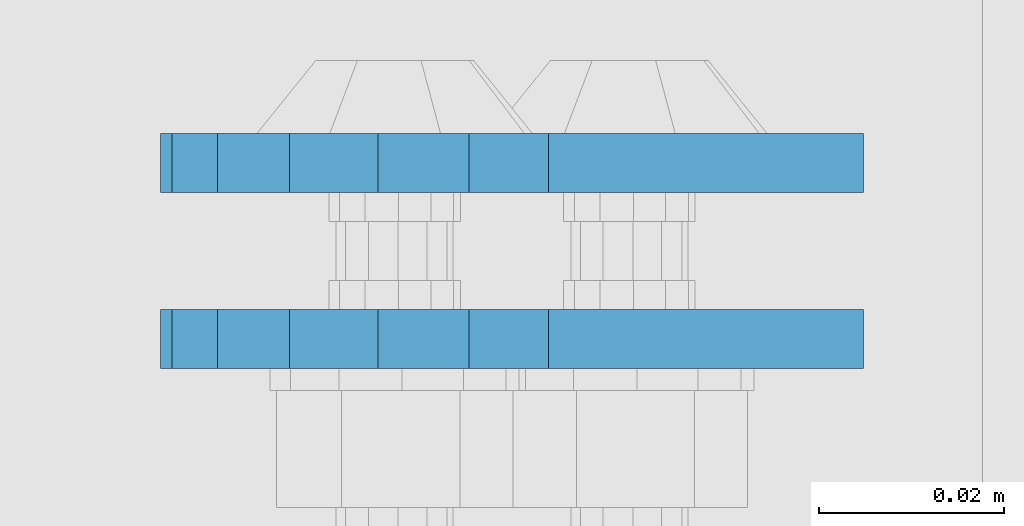
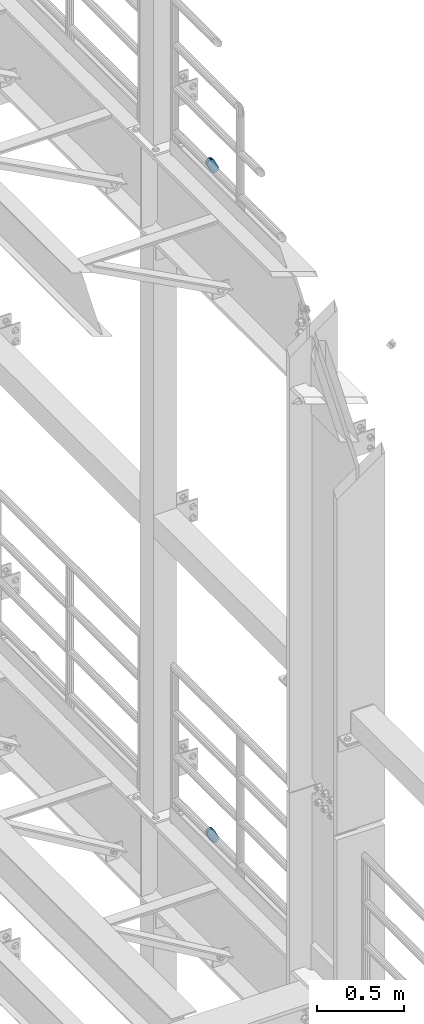
# One storey, part 1817 of 1876: 4 plates, 4 elements without a shape of their own.
"""IFC2X3 building model written with IfcOpenShell, lengths in millimetres."""

from ifc_helpers import new_model, si_unit, frame, origin_with_axes, place, context, subcontext, project, spatial, faceted_brep, material, type_object, element, aggregate, save


model = new_model("IFC2X3")

# Units and contexts
model_context = context("Model", 3, precision=1e-05, world=origin_with_axes())
body_context = subcontext(model_context, "Body", "Model", "MODEL_VIEW")
ifc_project = project(units=[si_unit("LENGTHUNIT", "METRE", prefix="MILLI"), si_unit("AREAUNIT", "SQUARE_METRE"), si_unit("VOLUMEUNIT", "CUBIC_METRE"), si_unit("MASSUNIT", "GRAM", prefix="KILO"), si_unit("TIMEUNIT", "SECOND"), si_unit("PLANEANGLEUNIT", "RADIAN"), si_unit("SOLIDANGLEUNIT", "STERADIAN"), si_unit("THERMODYNAMICTEMPERATUREUNIT", "DEGREE_CELSIUS"), si_unit("LUMINOUSINTENSITYUNIT", "LUMEN")], contexts=[model_context])

# Site, building, storey
site_placement = place(None, origin_with_axes())
site = spatial("IfcSite", under=ifc_project, at=site_placement, CompositionType="ELEMENT")
building_placement = place(site_placement, origin_with_axes())
building = spatial("IfcBuilding", under=site, at=building_placement, Name="Undefined", CompositionType="ELEMENT")
storey_placement = place(building_placement, origin_with_axes())
storey = spatial("IfcBuildingStorey", under=building, at=storey_placement, Name="Undefined", CompositionType="ELEMENT", Elevation=0.0)

# Assembly, plate
assembly_1_placement = place(storey_placement, origin_with_axes())
assembly_1 = element("IfcElementAssembly", 1, at=assembly_1_placement, inside=storey, Name="PLATE", AssemblyPlace="NOTDEFINED", PredefinedType="RIGID_FRAME")
ifc_material = material(Name="STEEL/A36")
plate_type = type_object("IfcPlateType", PredefinedType="NOTDEFINED")
plate_1_placement = place(assembly_1_placement, frame((7974.16265107448, 9642.4750023123, 17725.1776774809), z_axis=(-0.894427191199917, 1.49999996210681e-08, -0.447213595099955), x_axis=(0.447213595099955, -6.99999707257281e-09, -0.894427191199917)))
plate_1 = element("IfcPlate", 2, at=plate_1_placement, type_object=plate_type, material=ifc_material, Name="PLATE", context=body_context, shape_type="Brep", body=[
    faceted_brep([(-8.59611645864788e-07, -3.17499999999654, 25.3999987589127), (1.93345873884391, -3.17499999999382, 35.1201580589886), (1.93345873884391, 3.17500000000564, 35.1201580589886), (-8.59611645864788e-07, 3.17500000000382, 25.3999987589132), (7.43948648259902, -3.17499999999109, 43.3605112870105), (7.43948648259902, 3.17500000000928, 43.3605112870105), (15.6798395242777, -3.17499999998654, 48.8665393096448), (15.6798395242777, 3.17500000001382, 48.8665393096448), (25.3999987589095, -3.17499999998199, 50.7999992370592), (25.3999987589095, 3.17500000001837, 50.7999992370592), (82.196130752618, -3.17499999998381, 50.7999992370605), (82.196130752618, 3.17500000001655, 50.7999992370642), (91.9162897887145, -3.17499999997926, 48.8665393918873), (91.9162897887145, 3.1750000000211, 48.8665393918909), (100.156642725027, -3.17499999997472, 43.3605115909359), (100.156642725027, 3.17500000002565, 43.3605115909395), (105.662670525982, -3.17499999997108, 35.1201586546285), (105.662670525986, 3.17500000002929, 35.1201586546358), (107.596130371159, -3.17499999996744, 25.3999996185757), (107.596130371159, 3.17500000003292, 25.3999996185794), (105.662670525981, -3.17499999996471, 15.6798405824902), (105.662670525981, 3.17500000003565, 15.6798405824939), (100.156642725024, -3.17499999996471, 7.43948764618654), (100.156642725025, 3.17500000003565, 7.43948764619017), (91.9162897887127, -3.17499999996562, 1.93345984522784), (91.9162897887127, 3.17500000003474, 1.93345984523148), (82.196130752618, -3.17499999996835, 4.54747350886464e-11), (82.196130752618, 3.1750000000311, 4.91127138957381e-11), (25.399998758905, -3.17499999999018, -8.64019966684282e-12), (25.399998758905, 3.17500000001019, -8.64019966684282e-12), (15.679839921364, -3.17499999999382, 1.9334597629304), (15.679839921364, 3.17500000000655, 1.9334597629304), (7.43948709043525, -3.17499999999654, 7.43948734220839), (7.43948709043525, 3.17500000000382, 7.43948734220885), (1.93345923228208, -3.17499999999654, 15.6798399868012), (1.93345923228208, 3.17500000000291, 15.6798399868012)], [[[0, 1, 2, 3]], [[1, 4, 5, 2]], [[4, 6, 7, 5]], [[6, 8, 9, 7]], [[8, 10, 11, 9]], [[10, 12, 13, 11]], [[12, 14, 15, 13]], [[14, 16, 17, 15]], [[16, 18, 19, 17]], [[18, 20, 21, 19]], [[20, 22, 23, 21]], [[22, 24, 25, 23]], [[24, 26, 27, 25]], [[26, 28, 29, 27]], [[28, 30, 31, 29]], [[30, 32, 33, 31]], [[32, 34, 35, 33]], [[34, 0, 3, 35]], [[5, 7, 9, 11, 13, 15, 17, 19, 21, 23, 25, 27, 29, 31, 33, 35, 3, 2]], [[34, 32, 30, 28, 26, 24, 22, 20, 18, 16, 14, 12, 10, 8, 6, 4, 1, 0]]]),
])
aggregate(assembly_1, [plate_1])

assembly_2_placement = place(storey_placement, origin_with_axes())
assembly_2 = element("IfcElementAssembly", 3, at=assembly_2_placement, inside=storey, Name="PLATE", AssemblyPlace="NOTDEFINED", PredefinedType="RIGID_FRAME")
plate_2_placement = place(assembly_2_placement, frame((7974.16265167106, 9661.53619861698, 17725.1776774809), z_axis=(-0.894427191199917, 1.49999996210681e-08, -0.447213595099955), x_axis=(0.447213595099955, -6.99999707257281e-09, -0.894427191199917)))
plate_2 = element("IfcPlate", 4, at=plate_2_placement, type_object=plate_type, material=ifc_material, Name="PLATE", context=body_context, shape_type="Brep", body=[
    faceted_brep([(-8.59611645864788e-07, -3.17499999999654, 25.3999987589127), (1.93345873884391, -3.17499999999382, 35.1201580589886), (1.93345873884391, 3.17500000000564, 35.1201580589886), (-8.59611645864788e-07, 3.17500000000382, 25.3999987589132), (7.43948648259902, -3.17499999999109, 43.3605112870105), (7.43948648259902, 3.17500000000928, 43.3605112870105), (15.6798395242777, -3.17499999998654, 48.8665393096448), (15.6798395242777, 3.17500000001382, 48.8665393096448), (25.3999987589095, -3.17499999998199, 50.7999992370592), (25.3999987589095, 3.17500000001837, 50.7999992370592), (82.196130752618, -3.17499999998381, 50.7999992370605), (82.196130752618, 3.17500000001655, 50.7999992370642), (91.9162897887145, -3.17499999997926, 48.8665393918873), (91.9162897887145, 3.1750000000211, 48.8665393918909), (100.156642725027, -3.17499999997472, 43.3605115909359), (100.156642725027, 3.17500000002565, 43.3605115909395), (105.662670525982, -3.17499999997108, 35.1201586546285), (105.662670525986, 3.17500000002929, 35.1201586546358), (107.596130371159, -3.17499999996744, 25.3999996185757), (107.596130371159, 3.17500000003292, 25.3999996185794), (105.662670525981, -3.17499999996471, 15.6798405824902), (105.662670525981, 3.17500000003565, 15.6798405824939), (100.156642725024, -3.17499999996471, 7.43948764618654), (100.156642725025, 3.17500000003565, 7.43948764619017), (91.9162897887127, -3.17499999996562, 1.93345984522784), (91.9162897887127, 3.17500000003474, 1.93345984523148), (82.196130752618, -3.17499999996835, 4.54747350886464e-11), (82.196130752618, 3.1750000000311, 4.91127138957381e-11), (25.399998758905, -3.17499999999018, -8.64019966684282e-12), (25.399998758905, 3.17500000001019, -8.64019966684282e-12), (15.679839921364, -3.17499999999382, 1.9334597629304), (15.679839921364, 3.17500000000655, 1.9334597629304), (7.43948709043525, -3.17499999999654, 7.43948734220839), (7.43948709043525, 3.17500000000382, 7.43948734220885), (1.93345923228208, -3.17499999999654, 15.6798399868012), (1.93345923228208, 3.17500000000291, 15.6798399868012)], [[[0, 1, 2, 3]], [[1, 4, 5, 2]], [[4, 6, 7, 5]], [[6, 8, 9, 7]], [[8, 10, 11, 9]], [[10, 12, 13, 11]], [[12, 14, 15, 13]], [[14, 16, 17, 15]], [[16, 18, 19, 17]], [[18, 20, 21, 19]], [[20, 22, 23, 21]], [[22, 24, 25, 23]], [[24, 26, 27, 25]], [[26, 28, 29, 27]], [[28, 30, 31, 29]], [[30, 32, 33, 31]], [[32, 34, 35, 33]], [[34, 0, 3, 35]], [[5, 7, 9, 11, 13, 15, 17, 19, 21, 23, 25, 27, 29, 31, 33, 35, 3, 2]], [[34, 32, 30, 28, 26, 24, 22, 20, 18, 16, 14, 12, 10, 8, 6, 4, 1, 0]]]),
])
aggregate(assembly_2, [plate_2])

assembly_3_placement = place(storey_placement, origin_with_axes())
assembly_3 = element("IfcElementAssembly", 5, at=assembly_3_placement, inside=storey, Name="PLATE", AssemblyPlace="NOTDEFINED", PredefinedType="RIGID_FRAME")
plate_3_placement = place(assembly_3_placement, frame((7974.16265107448, 9642.4750023123, 13038.877677481), z_axis=(-0.894427191199917, 1.49999996210681e-08, -0.447213595099955), x_axis=(0.447213595099955, -6.99999707257281e-09, -0.894427191199917)))
plate_3 = element("IfcPlate", 6, at=plate_3_placement, type_object=plate_type, material=ifc_material, Name="PLATE", context=body_context, shape_type="Brep", body=[
    faceted_brep([(-8.59611645864788e-07, -3.17499999999654, 25.3999987589127), (1.93345873884391, -3.17499999999382, 35.1201580589886), (1.93345873884391, 3.17500000000564, 35.1201580589886), (-8.59611645864788e-07, 3.17500000000382, 25.3999987589132), (7.43948648259902, -3.17499999999109, 43.3605112870105), (7.43948648259902, 3.17500000000928, 43.3605112870105), (15.6798395242777, -3.17499999998654, 48.8665393096448), (15.6798395242777, 3.17500000001382, 48.8665393096448), (25.3999987589095, -3.17499999998199, 50.7999992370592), (25.3999987589095, 3.17500000001837, 50.7999992370592), (82.196130752618, -3.17499999998381, 50.7999992370605), (82.196130752618, 3.17500000001655, 50.7999992370642), (91.9162897887145, -3.17499999997926, 48.8665393918873), (91.9162897887145, 3.1750000000211, 48.8665393918909), (100.156642725027, -3.17499999997472, 43.3605115909359), (100.156642725027, 3.17500000002565, 43.3605115909395), (105.662670525982, -3.17499999997108, 35.1201586546285), (105.662670525986, 3.17500000002929, 35.1201586546358), (107.596130371159, -3.17499999996744, 25.3999996185757), (107.596130371159, 3.17500000003292, 25.3999996185794), (105.662670525981, -3.17499999996471, 15.6798405824902), (105.662670525981, 3.17500000003565, 15.6798405824939), (100.156642725024, -3.17499999996471, 7.43948764618654), (100.156642725025, 3.17500000003565, 7.43948764619017), (91.9162897887127, -3.17499999996562, 1.93345984522784), (91.9162897887127, 3.17500000003474, 1.93345984523148), (82.196130752618, -3.17499999996835, 4.54747350886464e-11), (82.196130752618, 3.1750000000311, 4.91127138957381e-11), (25.399998758905, -3.17499999999018, -8.64019966684282e-12), (25.399998758905, 3.17500000001019, -8.64019966684282e-12), (15.679839921364, -3.17499999999382, 1.9334597629304), (15.679839921364, 3.17500000000655, 1.9334597629304), (7.43948709043525, -3.17499999999654, 7.43948734220839), (7.43948709043525, 3.17500000000382, 7.43948734220885), (1.93345923228208, -3.17499999999654, 15.6798399868012), (1.93345923228208, 3.17500000000291, 15.6798399868012)], [[[0, 1, 2, 3]], [[1, 4, 5, 2]], [[4, 6, 7, 5]], [[6, 8, 9, 7]], [[8, 10, 11, 9]], [[10, 12, 13, 11]], [[12, 14, 15, 13]], [[14, 16, 17, 15]], [[16, 18, 19, 17]], [[18, 20, 21, 19]], [[20, 22, 23, 21]], [[22, 24, 25, 23]], [[24, 26, 27, 25]], [[26, 28, 29, 27]], [[28, 30, 31, 29]], [[30, 32, 33, 31]], [[32, 34, 35, 33]], [[34, 0, 3, 35]], [[5, 7, 9, 11, 13, 15, 17, 19, 21, 23, 25, 27, 29, 31, 33, 35, 3, 2]], [[34, 32, 30, 28, 26, 24, 22, 20, 18, 16, 14, 12, 10, 8, 6, 4, 1, 0]]]),
])
aggregate(assembly_3, [plate_3])

assembly_4_placement = place(storey_placement, origin_with_axes())
assembly_4 = element("IfcElementAssembly", 7, at=assembly_4_placement, inside=storey, Name="PLATE", AssemblyPlace="NOTDEFINED", PredefinedType="RIGID_FRAME")
plate_4_placement = place(assembly_4_placement, frame((7974.16265167106, 9661.53619861698, 13038.877677481), z_axis=(-0.894427191199917, 1.49999996210681e-08, -0.447213595099955), x_axis=(0.447213595099955, -6.99999707257281e-09, -0.894427191199917)))
plate_4 = element("IfcPlate", 8, at=plate_4_placement, type_object=plate_type, material=ifc_material, Name="PLATE", context=body_context, shape_type="Brep", body=[
    faceted_brep([(-8.59611645864788e-07, -3.17499999999654, 25.3999987589127), (1.93345873884391, -3.17499999999382, 35.1201580589886), (1.93345873884391, 3.17500000000564, 35.1201580589886), (-8.59611645864788e-07, 3.17500000000382, 25.3999987589132), (7.43948648259902, -3.17499999999109, 43.3605112870105), (7.43948648259902, 3.17500000000928, 43.3605112870105), (15.6798395242777, -3.17499999998654, 48.8665393096448), (15.6798395242777, 3.17500000001382, 48.8665393096448), (25.3999987589095, -3.17499999998199, 50.7999992370592), (25.3999987589095, 3.17500000001837, 50.7999992370592), (82.196130752618, -3.17499999998381, 50.7999992370605), (82.196130752618, 3.17500000001655, 50.7999992370642), (91.9162897887145, -3.17499999997926, 48.8665393918873), (91.9162897887145, 3.1750000000211, 48.8665393918909), (100.156642725027, -3.17499999997472, 43.3605115909359), (100.156642725027, 3.17500000002565, 43.3605115909395), (105.662670525982, -3.17499999997108, 35.1201586546285), (105.662670525986, 3.17500000002929, 35.1201586546358), (107.596130371159, -3.17499999996744, 25.3999996185757), (107.596130371159, 3.17500000003292, 25.3999996185794), (105.662670525981, -3.17499999996471, 15.6798405824902), (105.662670525981, 3.17500000003565, 15.6798405824939), (100.156642725024, -3.17499999996471, 7.43948764618654), (100.156642725025, 3.17500000003565, 7.43948764619017), (91.9162897887127, -3.17499999996562, 1.93345984522784), (91.9162897887127, 3.17500000003474, 1.93345984523148), (82.196130752618, -3.17499999996835, 4.54747350886464e-11), (82.196130752618, 3.1750000000311, 4.91127138957381e-11), (25.399998758905, -3.17499999999018, -8.64019966684282e-12), (25.399998758905, 3.17500000001019, -8.64019966684282e-12), (15.679839921364, -3.17499999999382, 1.9334597629304), (15.679839921364, 3.17500000000655, 1.9334597629304), (7.43948709043525, -3.17499999999654, 7.43948734220839), (7.43948709043525, 3.17500000000382, 7.43948734220885), (1.93345923228208, -3.17499999999654, 15.6798399868012), (1.93345923228208, 3.17500000000291, 15.6798399868012)], [[[0, 1, 2, 3]], [[1, 4, 5, 2]], [[4, 6, 7, 5]], [[6, 8, 9, 7]], [[8, 10, 11, 9]], [[10, 12, 13, 11]], [[12, 14, 15, 13]], [[14, 16, 17, 15]], [[16, 18, 19, 17]], [[18, 20, 21, 19]], [[20, 22, 23, 21]], [[22, 24, 25, 23]], [[24, 26, 27, 25]], [[26, 28, 29, 27]], [[28, 30, 31, 29]], [[30, 32, 33, 31]], [[32, 34, 35, 33]], [[34, 0, 3, 35]], [[5, 7, 9, 11, 13, 15, 17, 19, 21, 23, 25, 27, 29, 31, 33, 35, 3, 2]], [[34, 32, 30, 28, 26, 24, 22, 20, 18, 16, 14, 12, 10, 8, 6, 4, 1, 0]]]),
])
aggregate(assembly_4, [plate_4])

save(model, "model.ifc")
